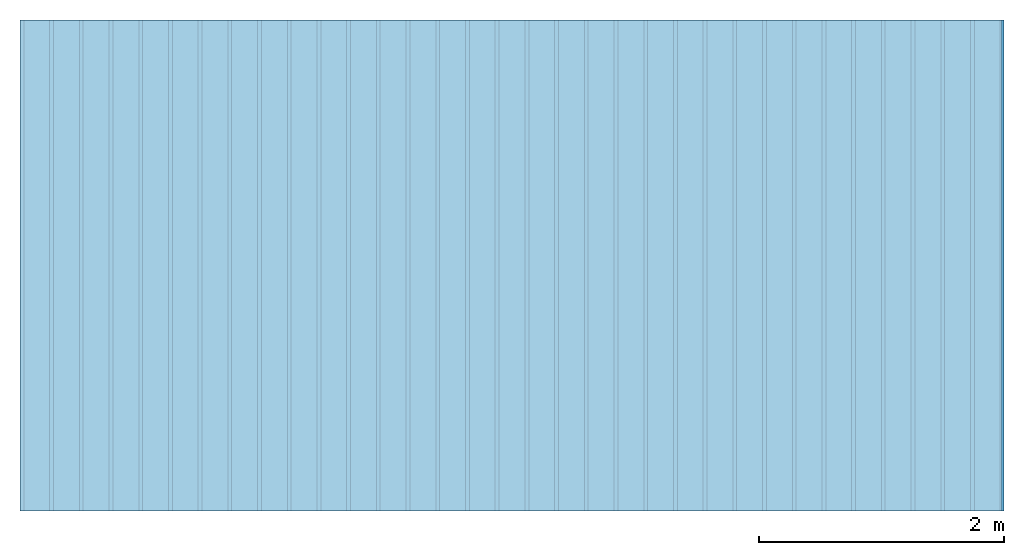
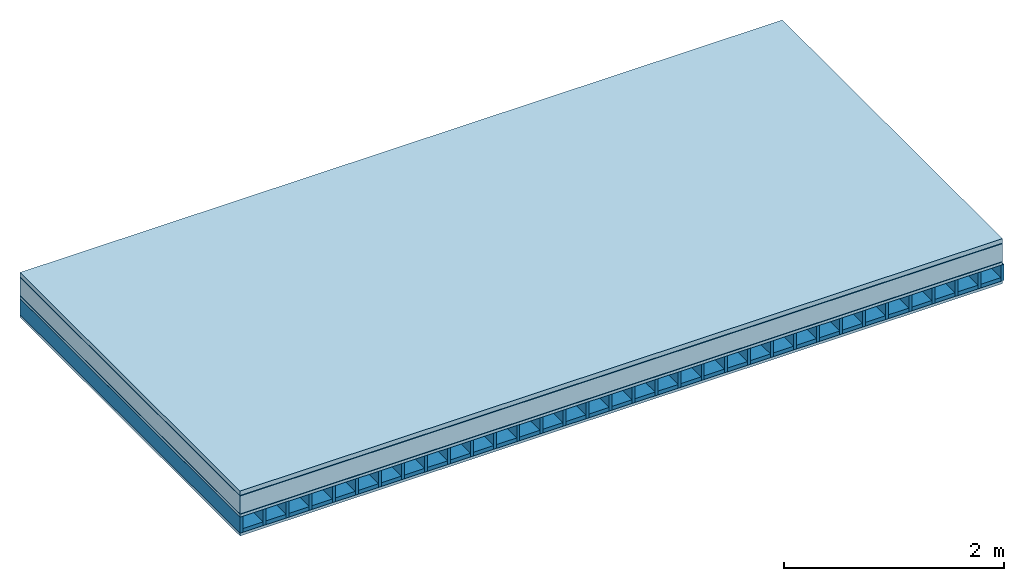
# One storey: 6 plates, 2 members, 1 element without a shape of its own.
"""IFC4 building model written with IfcOpenShell, lengths in metres."""

from ifc_helpers import new_model, si_unit, derived_unit, direction, frame, frame_2d, origin, origin_with_axes, place, context, project, spatial, rectangle, extrude, material, layer, layer_set, type_object, element, aggregate, save


model = new_model("IFC4")

# Units and contexts
plan_context = context("Plan", 3, precision=1e-05, world=origin(), true_north=direction((0.0, 1.0)))
model_context = context("Model", 3, precision=1e-05, world=origin(), true_north=direction((0.0, 1.0)))
ifc_project = project(units=[si_unit("LENGTHUNIT", "METRE"), derived_unit("SOUNDPRESSUREUNIT", [(si_unit("PRESSUREUNIT", "PASCAL", prefix="MICRO"), 0)]), si_unit("ENERGYUNIT", "JOULE", prefix="MEGA"), si_unit("MASSUNIT", "GRAM", prefix="KILO"), derived_unit("THERMALTRANSMITTANCEUNIT", [(si_unit("POWERUNIT", "WATT"), 1), (si_unit("AREAUNIT", "SQUARE_METRE"), -1), (si_unit("THERMODYNAMICTEMPERATUREUNIT", "KELVIN"), -1)]), derived_unit("AREADENSITYUNIT", [(si_unit("MASSUNIT", "GRAM", prefix="KILO"), 1), (si_unit("AREAUNIT", "SQUARE_METRE"), -1)]), derived_unit("USERDEFINED", [(si_unit("ENERGYUNIT", "JOULE", prefix="MEGA"), 1), (si_unit("AREAUNIT", "SQUARE_METRE"), -1)])], contexts=[plan_context, model_context])

# Site, building, storey
site = spatial("IfcSite", under=ifc_project)
building_placement = place(None, origin())
building = spatial("IfcBuilding", under=site, at=building_placement)
storey_placement = place(building_placement, origin())
storey = spatial("IfcBuildingStorey", under=building, at=storey_placement)

# Slab, members, plates
ifc_material_1 = material(Name="Gravel 8-16mm", Category="03.011")
ifc_layer_1 = layer(ifc_material_1, 0.05, Name="Use and protection layer 2")
ifc_material_2 = material(Name="Roofing underlay", Category="09.008")
ifc_layer_2 = layer(ifc_material_2, 0.005, Name="Under the roof")
ifc_material_3 = material(Category="10.004")
ifc_layer_3 = layer(ifc_material_3, 0.2, Name="Exterior insulation layer 1")
ifc_material_4 = material(Name="Vapor barrier bituminous", Category="09.003")
ifc_layer_4 = layer(ifc_material_4, 0.004, Name="layer / temporary roof")
ifc_material_5 = material(Name="surface element sheathing above")
ifc_layer_5 = layer(ifc_material_5, 0.031, Name="above 1st layer")
ifc_layer_6 = layer(None, 0.178, Name="Support")
ifc_material_6 = material(Name="surface element sheathing below")
ifc_layer_7 = layer(ifc_material_6, 0.031, Name="Lower layer 1")
ifc_layer_set = layer_set([ifc_layer_1, ifc_layer_2, ifc_layer_3, ifc_layer_4, ifc_layer_5, ifc_layer_6, ifc_layer_7])
slab_type = type_object("IfcSlabType", Name="F0127", PredefinedType="NOTDEFINED", material=ifc_layer_set)
slab_placement = place(None, frame((0.0, 0.0, 0.0), z_axis=(0.0, 0.0, -1.0), x_axis=(1.0, 0.0, 0.0)))
slab = element("IfcSlab", 1, at=slab_placement, inside=storey, type_object=slab_type, material=ifc_layer_set, Name="Slab #1")
ifc_material_7 = material(Name="surface element LFE")
member_1_placement = place(slab_placement, origin())
member_1 = element("IfcMember", 2, at=member_1_placement, material=ifc_material_7, Name="Support", context=plan_context, shape_type="SweptSolid", body=[
    extrude(rectangle(XDim=0.031, YDim=0.178, at=frame_2d((0.0155, 0.089), x_axis=(1.0, 0.0))), frame((0.0, 4.0, 0.29), z_axis=(0.0, -1.0, 0.0), x_axis=(1.0, 0.0, 0.0)), (0.0, 0.0, 1.0), 4.0),
    extrude(rectangle(XDim=0.031, YDim=0.178, at=frame_2d((0.0155, 0.089), x_axis=(1.0, 0.0))), frame((0.242, 4.0, 0.29), z_axis=(0.0, -1.0, 0.0), x_axis=(1.0, 0.0, 0.0)), (0.0, 0.0, 1.0), 4.0),
    extrude(rectangle(XDim=0.031, YDim=0.178, at=frame_2d((0.0155, 0.089), x_axis=(1.0, 0.0))), frame((0.484, 4.0, 0.29), z_axis=(0.0, -1.0, 0.0), x_axis=(1.0, 0.0, 0.0)), (0.0, 0.0, 1.0), 4.0),
    extrude(rectangle(XDim=0.031, YDim=0.178, at=frame_2d((0.0155, 0.089), x_axis=(1.0, 0.0))), frame((0.726, 4.0, 0.29), z_axis=(0.0, -1.0, 0.0), x_axis=(1.0, 0.0, 0.0)), (0.0, 0.0, 1.0), 4.0),
    extrude(rectangle(XDim=0.031, YDim=0.178, at=frame_2d((0.0155, 0.089), x_axis=(1.0, 0.0))), frame((0.968, 4.0, 0.29), z_axis=(0.0, -1.0, 0.0), x_axis=(1.0, 0.0, 0.0)), (0.0, 0.0, 1.0), 4.0),
    extrude(rectangle(XDim=0.031, YDim=0.178, at=frame_2d((0.0155, 0.089), x_axis=(1.0, 0.0))), frame((1.21, 4.0, 0.29), z_axis=(0.0, -1.0, 0.0), x_axis=(1.0, 0.0, 0.0)), (0.0, 0.0, 1.0), 4.0),
    extrude(rectangle(XDim=0.031, YDim=0.178, at=frame_2d((0.0155, 0.089), x_axis=(1.0, 0.0))), frame((1.452, 4.0, 0.29), z_axis=(0.0, -1.0, 0.0), x_axis=(1.0, 0.0, 0.0)), (0.0, 0.0, 1.0), 4.0),
    extrude(rectangle(XDim=0.031, YDim=0.178, at=frame_2d((0.0155, 0.089), x_axis=(1.0, 0.0))), frame((1.694, 4.0, 0.29), z_axis=(0.0, -1.0, 0.0), x_axis=(1.0, 0.0, 0.0)), (0.0, 0.0, 1.0), 4.0),
    extrude(rectangle(XDim=0.031, YDim=0.178, at=frame_2d((0.0155, 0.089), x_axis=(1.0, 0.0))), frame((1.936, 4.0, 0.29), z_axis=(0.0, -1.0, 0.0), x_axis=(1.0, 0.0, 0.0)), (0.0, 0.0, 1.0), 4.0),
    extrude(rectangle(XDim=0.031, YDim=0.178, at=frame_2d((0.0155, 0.089), x_axis=(1.0, 0.0))), frame((2.178, 4.0, 0.29), z_axis=(0.0, -1.0, 0.0), x_axis=(1.0, 0.0, 0.0)), (0.0, 0.0, 1.0), 4.0),
    extrude(rectangle(XDim=0.031, YDim=0.178, at=frame_2d((0.0155, 0.089), x_axis=(1.0, 0.0))), frame((2.42, 4.0, 0.29), z_axis=(0.0, -1.0, 0.0), x_axis=(1.0, 0.0, 0.0)), (0.0, 0.0, 1.0), 4.0),
    extrude(rectangle(XDim=0.031, YDim=0.178, at=frame_2d((0.0155, 0.089), x_axis=(1.0, 0.0))), frame((2.662, 4.0, 0.29), z_axis=(0.0, -1.0, 0.0), x_axis=(1.0, 0.0, 0.0)), (0.0, 0.0, 1.0), 4.0),
    extrude(rectangle(XDim=0.031, YDim=0.178, at=frame_2d((0.0155, 0.089), x_axis=(1.0, 0.0))), frame((2.904, 4.0, 0.29), z_axis=(0.0, -1.0, 0.0), x_axis=(1.0, 0.0, 0.0)), (0.0, 0.0, 1.0), 4.0),
    extrude(rectangle(XDim=0.031, YDim=0.178, at=frame_2d((0.0155, 0.089), x_axis=(1.0, 0.0))), frame((3.146, 4.0, 0.29), z_axis=(0.0, -1.0, 0.0), x_axis=(1.0, 0.0, 0.0)), (0.0, 0.0, 1.0), 4.0),
    extrude(rectangle(XDim=0.031, YDim=0.178, at=frame_2d((0.0155, 0.089), x_axis=(1.0, 0.0))), frame((3.388, 4.0, 0.29), z_axis=(0.0, -1.0, 0.0), x_axis=(1.0, 0.0, 0.0)), (0.0, 0.0, 1.0), 4.0),
    extrude(rectangle(XDim=0.031, YDim=0.178, at=frame_2d((0.0155, 0.089), x_axis=(1.0, 0.0))), frame((3.63, 4.0, 0.29), z_axis=(0.0, -1.0, 0.0), x_axis=(1.0, 0.0, 0.0)), (0.0, 0.0, 1.0), 4.0),
    extrude(rectangle(XDim=0.031, YDim=0.178, at=frame_2d((0.0155, 0.089), x_axis=(1.0, 0.0))), frame((3.872, 4.0, 0.29), z_axis=(0.0, -1.0, 0.0), x_axis=(1.0, 0.0, 0.0)), (0.0, 0.0, 1.0), 4.0),
    extrude(rectangle(XDim=0.031, YDim=0.178, at=frame_2d((0.0155, 0.089), x_axis=(1.0, 0.0))), frame((4.114, 4.0, 0.29), z_axis=(0.0, -1.0, 0.0), x_axis=(1.0, 0.0, 0.0)), (0.0, 0.0, 1.0), 4.0),
    extrude(rectangle(XDim=0.031, YDim=0.178, at=frame_2d((0.0155, 0.089), x_axis=(1.0, 0.0))), frame((4.356, 4.0, 0.29), z_axis=(0.0, -1.0, 0.0), x_axis=(1.0, 0.0, 0.0)), (0.0, 0.0, 1.0), 4.0),
    extrude(rectangle(XDim=0.031, YDim=0.178, at=frame_2d((0.0155, 0.089), x_axis=(1.0, 0.0))), frame((4.598, 4.0, 0.29), z_axis=(0.0, -1.0, 0.0), x_axis=(1.0, 0.0, 0.0)), (0.0, 0.0, 1.0), 4.0),
    extrude(rectangle(XDim=0.031, YDim=0.178, at=frame_2d((0.0155, 0.089), x_axis=(1.0, 0.0))), frame((4.84, 4.0, 0.29), z_axis=(0.0, -1.0, 0.0), x_axis=(1.0, 0.0, 0.0)), (0.0, 0.0, 1.0), 4.0),
    extrude(rectangle(XDim=0.031, YDim=0.178, at=frame_2d((0.0155, 0.089), x_axis=(1.0, 0.0))), frame((5.082, 4.0, 0.29), z_axis=(0.0, -1.0, 0.0), x_axis=(1.0, 0.0, 0.0)), (0.0, 0.0, 1.0), 4.0),
    extrude(rectangle(XDim=0.031, YDim=0.178, at=frame_2d((0.0155, 0.089), x_axis=(1.0, 0.0))), frame((5.324, 4.0, 0.29), z_axis=(0.0, -1.0, 0.0), x_axis=(1.0, 0.0, 0.0)), (0.0, 0.0, 1.0), 4.0),
    extrude(rectangle(XDim=0.031, YDim=0.178, at=frame_2d((0.0155, 0.089), x_axis=(1.0, 0.0))), frame((5.566, 4.0, 0.29), z_axis=(0.0, -1.0, 0.0), x_axis=(1.0, 0.0, 0.0)), (0.0, 0.0, 1.0), 4.0),
    extrude(rectangle(XDim=0.031, YDim=0.178, at=frame_2d((0.0155, 0.089), x_axis=(1.0, 0.0))), frame((5.808, 4.0, 0.29), z_axis=(0.0, -1.0, 0.0), x_axis=(1.0, 0.0, 0.0)), (0.0, 0.0, 1.0), 4.0),
    extrude(rectangle(XDim=0.031, YDim=0.178, at=frame_2d((0.0155, 0.089), x_axis=(1.0, 0.0))), frame((6.05, 4.0, 0.29), z_axis=(0.0, -1.0, 0.0), x_axis=(1.0, 0.0, 0.0)), (0.0, 0.0, 1.0), 4.0),
    extrude(rectangle(XDim=0.031, YDim=0.178, at=frame_2d((0.0155, 0.089), x_axis=(1.0, 0.0))), frame((6.292, 4.0, 0.29), z_axis=(0.0, -1.0, 0.0), x_axis=(1.0, 0.0, 0.0)), (0.0, 0.0, 1.0), 4.0),
    extrude(rectangle(XDim=0.031, YDim=0.178, at=frame_2d((0.0155, 0.089), x_axis=(1.0, 0.0))), frame((6.534, 4.0, 0.29), z_axis=(0.0, -1.0, 0.0), x_axis=(1.0, 0.0, 0.0)), (0.0, 0.0, 1.0), 4.0),
    extrude(rectangle(XDim=0.031, YDim=0.178, at=frame_2d((0.0155, 0.089), x_axis=(1.0, 0.0))), frame((6.776, 4.0, 0.29), z_axis=(0.0, -1.0, 0.0), x_axis=(1.0, 0.0, 0.0)), (0.0, 0.0, 1.0), 4.0),
    extrude(rectangle(XDim=0.031, YDim=0.178, at=frame_2d((0.0155, 0.089), x_axis=(1.0, 0.0))), frame((7.018, 4.0, 0.29), z_axis=(0.0, -1.0, 0.0), x_axis=(1.0, 0.0, 0.0)), (0.0, 0.0, 1.0), 4.0),
    extrude(rectangle(XDim=0.031, YDim=0.178, at=frame_2d((0.0155, 0.089), x_axis=(1.0, 0.0))), frame((7.26, 4.0, 0.29), z_axis=(0.0, -1.0, 0.0), x_axis=(1.0, 0.0, 0.0)), (0.0, 0.0, 1.0), 4.0),
    extrude(rectangle(XDim=0.031, YDim=0.178, at=frame_2d((0.0155, 0.089), x_axis=(1.0, 0.0))), frame((7.502, 4.0, 0.29), z_axis=(0.0, -1.0, 0.0), x_axis=(1.0, 0.0, 0.0)), (0.0, 0.0, 1.0), 4.0),
    extrude(rectangle(XDim=0.031, YDim=0.178, at=frame_2d((0.0155, 0.089), x_axis=(1.0, 0.0))), frame((7.744, 4.0, 0.29), z_axis=(0.0, -1.0, 0.0), x_axis=(1.0, 0.0, 0.0)), (0.0, 0.0, 1.0), 4.0),
    extrude(rectangle(XDim=0.031, YDim=0.178, at=frame_2d((0.0155, 0.089), x_axis=(1.0, 0.0))), frame((7.986, 4.0, 0.29), z_axis=(0.0, -1.0, 0.0), x_axis=(1.0, 0.0, 0.0)), (0.0, 0.0, 1.0), 4.0),
])
ifc_material_8 = material()
member_2_placement = place(slab_placement, origin())
member_2 = element("IfcMember", 3, at=member_2_placement, material=ifc_material_8, Name="in supporting structure", context=plan_context, shape_type="SweptSolid", body=[
    extrude(rectangle(XDim=0.211, YDim=0.041, at=frame_2d((0.1055, 0.0205), x_axis=(1.0, 0.0))), frame((0.031, 4.0, 0.427), z_axis=(0.0, -1.0, 0.0), x_axis=(1.0, 0.0, 0.0)), (0.0, 0.0, 1.0), 4.0),
    extrude(rectangle(XDim=0.211, YDim=0.041, at=frame_2d((0.1055, 0.0205), x_axis=(1.0, 0.0))), frame((0.273, 4.0, 0.427), z_axis=(0.0, -1.0, 0.0), x_axis=(1.0, 0.0, 0.0)), (0.0, 0.0, 1.0), 4.0),
    extrude(rectangle(XDim=0.211, YDim=0.041, at=frame_2d((0.1055, 0.0205), x_axis=(1.0, 0.0))), frame((0.515, 4.0, 0.427), z_axis=(0.0, -1.0, 0.0), x_axis=(1.0, 0.0, 0.0)), (0.0, 0.0, 1.0), 4.0),
    extrude(rectangle(XDim=0.211, YDim=0.041, at=frame_2d((0.1055, 0.0205), x_axis=(1.0, 0.0))), frame((0.757, 4.0, 0.427), z_axis=(0.0, -1.0, 0.0), x_axis=(1.0, 0.0, 0.0)), (0.0, 0.0, 1.0), 4.0),
    extrude(rectangle(XDim=0.211, YDim=0.041, at=frame_2d((0.1055, 0.0205), x_axis=(1.0, 0.0))), frame((0.999, 4.0, 0.427), z_axis=(0.0, -1.0, 0.0), x_axis=(1.0, 0.0, 0.0)), (0.0, 0.0, 1.0), 4.0),
    extrude(rectangle(XDim=0.211, YDim=0.041, at=frame_2d((0.1055, 0.0205), x_axis=(1.0, 0.0))), frame((1.241, 4.0, 0.427), z_axis=(0.0, -1.0, 0.0), x_axis=(1.0, 0.0, 0.0)), (0.0, 0.0, 1.0), 4.0),
    extrude(rectangle(XDim=0.211, YDim=0.041, at=frame_2d((0.1055, 0.0205), x_axis=(1.0, 0.0))), frame((1.483, 4.0, 0.427), z_axis=(0.0, -1.0, 0.0), x_axis=(1.0, 0.0, 0.0)), (0.0, 0.0, 1.0), 4.0),
    extrude(rectangle(XDim=0.211, YDim=0.041, at=frame_2d((0.1055, 0.0205), x_axis=(1.0, 0.0))), frame((1.725, 4.0, 0.427), z_axis=(0.0, -1.0, 0.0), x_axis=(1.0, 0.0, 0.0)), (0.0, 0.0, 1.0), 4.0),
    extrude(rectangle(XDim=0.211, YDim=0.041, at=frame_2d((0.1055, 0.0205), x_axis=(1.0, 0.0))), frame((1.967, 4.0, 0.427), z_axis=(0.0, -1.0, 0.0), x_axis=(1.0, 0.0, 0.0)), (0.0, 0.0, 1.0), 4.0),
    extrude(rectangle(XDim=0.211, YDim=0.041, at=frame_2d((0.1055, 0.0205), x_axis=(1.0, 0.0))), frame((2.209, 4.0, 0.427), z_axis=(0.0, -1.0, 0.0), x_axis=(1.0, 0.0, 0.0)), (0.0, 0.0, 1.0), 4.0),
    extrude(rectangle(XDim=0.211, YDim=0.041, at=frame_2d((0.1055, 0.0205), x_axis=(1.0, 0.0))), frame((2.451, 4.0, 0.427), z_axis=(0.0, -1.0, 0.0), x_axis=(1.0, 0.0, 0.0)), (0.0, 0.0, 1.0), 4.0),
    extrude(rectangle(XDim=0.211, YDim=0.041, at=frame_2d((0.1055, 0.0205), x_axis=(1.0, 0.0))), frame((2.693, 4.0, 0.427), z_axis=(0.0, -1.0, 0.0), x_axis=(1.0, 0.0, 0.0)), (0.0, 0.0, 1.0), 4.0),
    extrude(rectangle(XDim=0.211, YDim=0.041, at=frame_2d((0.1055, 0.0205), x_axis=(1.0, 0.0))), frame((2.935, 4.0, 0.427), z_axis=(0.0, -1.0, 0.0), x_axis=(1.0, 0.0, 0.0)), (0.0, 0.0, 1.0), 4.0),
    extrude(rectangle(XDim=0.211, YDim=0.041, at=frame_2d((0.1055, 0.0205), x_axis=(1.0, 0.0))), frame((3.177, 4.0, 0.427), z_axis=(0.0, -1.0, 0.0), x_axis=(1.0, 0.0, 0.0)), (0.0, 0.0, 1.0), 4.0),
    extrude(rectangle(XDim=0.211, YDim=0.041, at=frame_2d((0.1055, 0.0205), x_axis=(1.0, 0.0))), frame((3.419, 4.0, 0.427), z_axis=(0.0, -1.0, 0.0), x_axis=(1.0, 0.0, 0.0)), (0.0, 0.0, 1.0), 4.0),
    extrude(rectangle(XDim=0.211, YDim=0.041, at=frame_2d((0.1055, 0.0205), x_axis=(1.0, 0.0))), frame((3.661, 4.0, 0.427), z_axis=(0.0, -1.0, 0.0), x_axis=(1.0, 0.0, 0.0)), (0.0, 0.0, 1.0), 4.0),
    extrude(rectangle(XDim=0.211, YDim=0.041, at=frame_2d((0.1055, 0.0205), x_axis=(1.0, 0.0))), frame((3.903, 4.0, 0.427), z_axis=(0.0, -1.0, 0.0), x_axis=(1.0, 0.0, 0.0)), (0.0, 0.0, 1.0), 4.0),
    extrude(rectangle(XDim=0.211, YDim=0.041, at=frame_2d((0.1055, 0.0205), x_axis=(1.0, 0.0))), frame((4.145, 4.0, 0.427), z_axis=(0.0, -1.0, 0.0), x_axis=(1.0, 0.0, 0.0)), (0.0, 0.0, 1.0), 4.0),
    extrude(rectangle(XDim=0.211, YDim=0.041, at=frame_2d((0.1055, 0.0205), x_axis=(1.0, 0.0))), frame((4.387, 4.0, 0.427), z_axis=(0.0, -1.0, 0.0), x_axis=(1.0, 0.0, 0.0)), (0.0, 0.0, 1.0), 4.0),
    extrude(rectangle(XDim=0.211, YDim=0.041, at=frame_2d((0.1055, 0.0205), x_axis=(1.0, 0.0))), frame((4.629, 4.0, 0.427), z_axis=(0.0, -1.0, 0.0), x_axis=(1.0, 0.0, 0.0)), (0.0, 0.0, 1.0), 4.0),
    extrude(rectangle(XDim=0.211, YDim=0.041, at=frame_2d((0.1055, 0.0205), x_axis=(1.0, 0.0))), frame((4.871, 4.0, 0.427), z_axis=(0.0, -1.0, 0.0), x_axis=(1.0, 0.0, 0.0)), (0.0, 0.0, 1.0), 4.0),
    extrude(rectangle(XDim=0.211, YDim=0.041, at=frame_2d((0.1055, 0.0205), x_axis=(1.0, 0.0))), frame((5.113, 4.0, 0.427), z_axis=(0.0, -1.0, 0.0), x_axis=(1.0, 0.0, 0.0)), (0.0, 0.0, 1.0), 4.0),
    extrude(rectangle(XDim=0.211, YDim=0.041, at=frame_2d((0.1055, 0.0205), x_axis=(1.0, 0.0))), frame((5.355, 4.0, 0.427), z_axis=(0.0, -1.0, 0.0), x_axis=(1.0, 0.0, 0.0)), (0.0, 0.0, 1.0), 4.0),
    extrude(rectangle(XDim=0.211, YDim=0.041, at=frame_2d((0.1055, 0.0205), x_axis=(1.0, 0.0))), frame((5.597, 4.0, 0.427), z_axis=(0.0, -1.0, 0.0), x_axis=(1.0, 0.0, 0.0)), (0.0, 0.0, 1.0), 4.0),
    extrude(rectangle(XDim=0.211, YDim=0.041, at=frame_2d((0.1055, 0.0205), x_axis=(1.0, 0.0))), frame((5.839, 4.0, 0.427), z_axis=(0.0, -1.0, 0.0), x_axis=(1.0, 0.0, 0.0)), (0.0, 0.0, 1.0), 4.0),
    extrude(rectangle(XDim=0.211, YDim=0.041, at=frame_2d((0.1055, 0.0205), x_axis=(1.0, 0.0))), frame((6.081, 4.0, 0.427), z_axis=(0.0, -1.0, 0.0), x_axis=(1.0, 0.0, 0.0)), (0.0, 0.0, 1.0), 4.0),
    extrude(rectangle(XDim=0.211, YDim=0.041, at=frame_2d((0.1055, 0.0205), x_axis=(1.0, 0.0))), frame((6.323, 4.0, 0.427), z_axis=(0.0, -1.0, 0.0), x_axis=(1.0, 0.0, 0.0)), (0.0, 0.0, 1.0), 4.0),
    extrude(rectangle(XDim=0.211, YDim=0.041, at=frame_2d((0.1055, 0.0205), x_axis=(1.0, 0.0))), frame((6.565, 4.0, 0.427), z_axis=(0.0, -1.0, 0.0), x_axis=(1.0, 0.0, 0.0)), (0.0, 0.0, 1.0), 4.0),
    extrude(rectangle(XDim=0.211, YDim=0.041, at=frame_2d((0.1055, 0.0205), x_axis=(1.0, 0.0))), frame((6.807, 4.0, 0.427), z_axis=(0.0, -1.0, 0.0), x_axis=(1.0, 0.0, 0.0)), (0.0, 0.0, 1.0), 4.0),
    extrude(rectangle(XDim=0.211, YDim=0.041, at=frame_2d((0.1055, 0.0205), x_axis=(1.0, 0.0))), frame((7.049, 4.0, 0.427), z_axis=(0.0, -1.0, 0.0), x_axis=(1.0, 0.0, 0.0)), (0.0, 0.0, 1.0), 4.0),
    extrude(rectangle(XDim=0.211, YDim=0.041, at=frame_2d((0.1055, 0.0205), x_axis=(1.0, 0.0))), frame((7.291, 4.0, 0.427), z_axis=(0.0, -1.0, 0.0), x_axis=(1.0, 0.0, 0.0)), (0.0, 0.0, 1.0), 4.0),
    extrude(rectangle(XDim=0.211, YDim=0.041, at=frame_2d((0.1055, 0.0205), x_axis=(1.0, 0.0))), frame((7.533, 4.0, 0.427), z_axis=(0.0, -1.0, 0.0), x_axis=(1.0, 0.0, 0.0)), (0.0, 0.0, 1.0), 4.0),
    extrude(rectangle(XDim=0.211, YDim=0.041, at=frame_2d((0.1055, 0.0205), x_axis=(1.0, 0.0))), frame((7.775, 4.0, 0.427), z_axis=(0.0, -1.0, 0.0), x_axis=(1.0, 0.0, 0.0)), (0.0, 0.0, 1.0), 4.0),
])
plate_1_placement = place(slab_placement, origin())
plate_1 = element("IfcPlate", 4, at=plate_1_placement, material=ifc_material_1, Name="Use and protection layer 2", context=plan_context, shape_type="SweptSolid", body=[
    extrude(rectangle(XDim=8.0, YDim=4.0, at=frame_2d((4.0, 2.0), x_axis=(1.0, 0.0))), origin_with_axes(), (0.0, 0.0, 1.0), 0.05),
])
plate_2_placement = place(slab_placement, origin())
plate_2 = element("IfcPlate", 5, at=plate_2_placement, material=ifc_material_2, Name="Under the roof", context=plan_context, shape_type="SweptSolid", body=[
    extrude(rectangle(XDim=8.0, YDim=4.0, at=frame_2d((4.0, 2.0), x_axis=(1.0, 0.0))), frame((0.0, 0.0, 0.05), z_axis=(0.0, 0.0, 1.0), x_axis=(1.0, 0.0, 0.0)), (0.0, 0.0, 1.0), 0.005),
])
plate_3_placement = place(slab_placement, origin())
plate_3 = element("IfcPlate", 6, at=plate_3_placement, material=ifc_material_3, Name="Exterior insulation layer 1", context=plan_context, shape_type="SweptSolid", body=[
    extrude(rectangle(XDim=8.0, YDim=4.0, at=frame_2d((4.0, 2.0), x_axis=(1.0, 0.0))), frame((0.0, 0.0, 0.055), z_axis=(0.0, 0.0, 1.0), x_axis=(1.0, 0.0, 0.0)), (0.0, 0.0, 1.0), 0.2),
])
plate_4_placement = place(slab_placement, origin())
plate_4 = element("IfcPlate", 7, at=plate_4_placement, material=ifc_material_4, Name="layer / temporary roof", context=plan_context, shape_type="SweptSolid", body=[
    extrude(rectangle(XDim=8.0, YDim=4.0, at=frame_2d((4.0, 2.0), x_axis=(1.0, 0.0))), frame((0.0, 0.0, 0.255), z_axis=(0.0, 0.0, 1.0), x_axis=(1.0, 0.0, 0.0)), (0.0, 0.0, 1.0), 0.004),
])
plate_5_placement = place(slab_placement, origin())
plate_5 = element("IfcPlate", 8, at=plate_5_placement, material=ifc_material_5, Name="above 1st layer", context=plan_context, shape_type="SweptSolid", body=[
    extrude(rectangle(XDim=8.0, YDim=4.0, at=frame_2d((4.0, 2.0), x_axis=(1.0, 0.0))), frame((0.0, 0.0, 0.259), z_axis=(0.0, 0.0, 1.0), x_axis=(1.0, 0.0, 0.0)), (0.0, 0.0, 1.0), 0.031),
])
plate_6_placement = place(slab_placement, origin())
plate_6 = element("IfcPlate", 9, at=plate_6_placement, material=ifc_material_6, Name="Lower layer 1", context=plan_context, shape_type="SweptSolid", body=[
    extrude(rectangle(XDim=8.0, YDim=4.0, at=frame_2d((4.0, 2.0), x_axis=(1.0, 0.0))), frame((0.0, 0.0, 0.468), z_axis=(0.0, 0.0, 1.0), x_axis=(1.0, 0.0, 0.0)), (0.0, 0.0, 1.0), 0.031),
])
aggregate(slab, [plate_1, plate_2, plate_3, plate_4, plate_5, member_1, member_2, plate_6])

save(model, "model.ifc")
